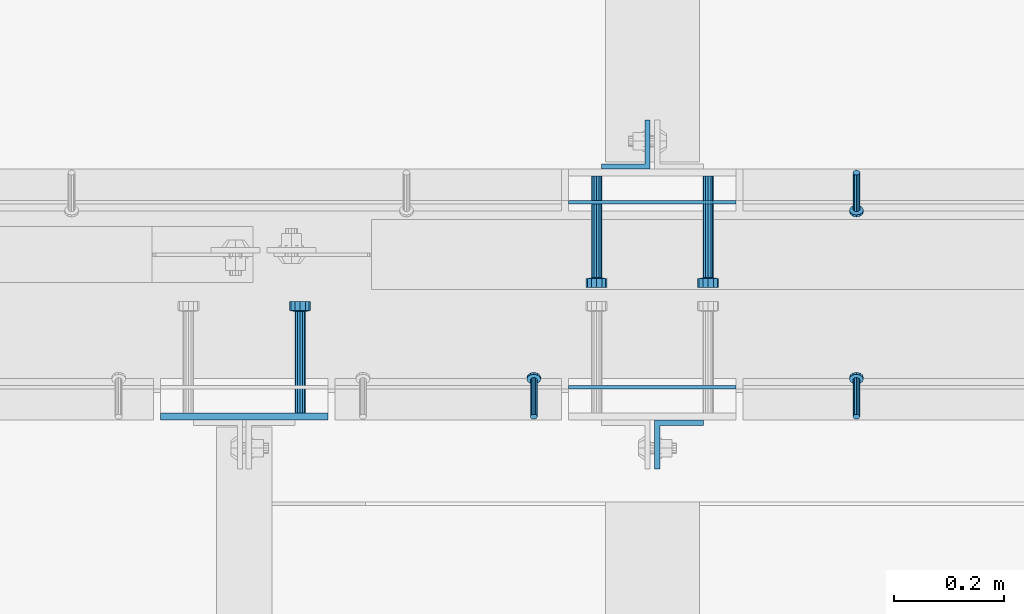
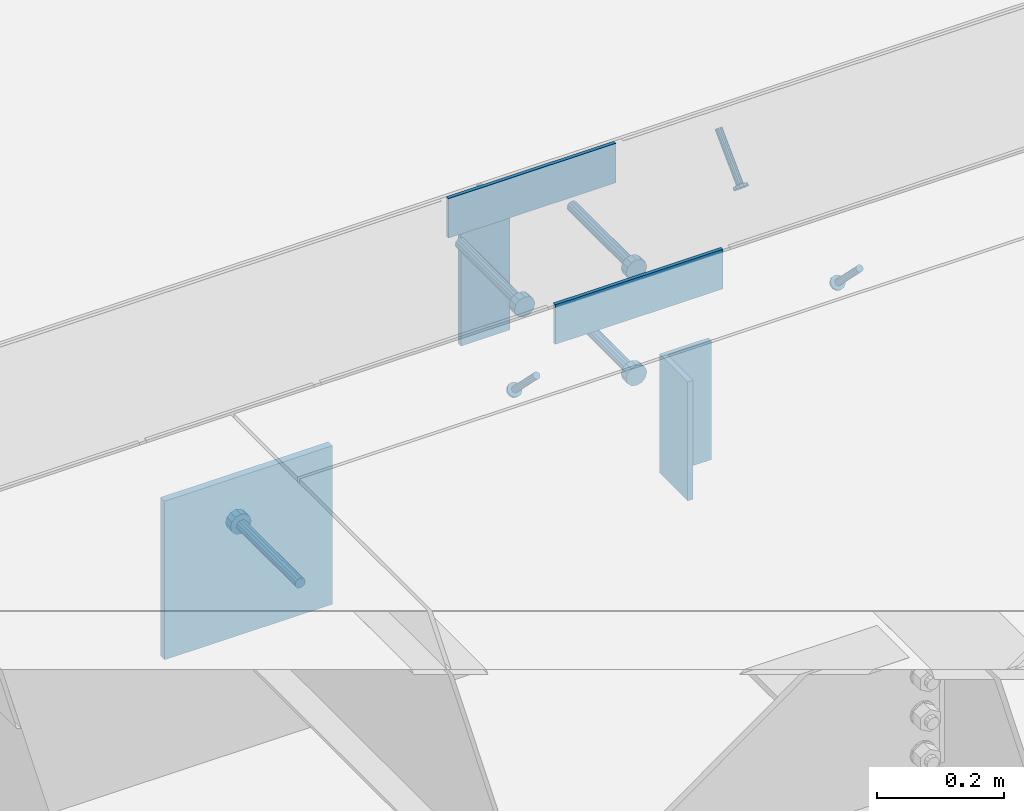
# One storey, part 2009 of 3843: 9 beams, 3 members, 8 elements without a shape of their own.
"""IFC2X3 building model written with IfcOpenShell, lengths in millimetres."""

from ifc_helpers import new_model, si_unit, frame, origin_with_axes, place, context, subcontext, project, spatial, faceted_brep, material, type_object, element, aggregate, save


model = new_model("IFC2X3")

# Units and contexts
model_context = context("Model", 3, precision=1e-05, world=origin_with_axes())
body_context = subcontext(model_context, "Body", "Model", "MODEL_VIEW")
ifc_project = project(units=[si_unit("LENGTHUNIT", "METRE", prefix="MILLI"), si_unit("AREAUNIT", "SQUARE_METRE"), si_unit("VOLUMEUNIT", "CUBIC_METRE"), si_unit("MASSUNIT", "GRAM", prefix="KILO"), si_unit("TIMEUNIT", "SECOND"), si_unit("PLANEANGLEUNIT", "RADIAN"), si_unit("SOLIDANGLEUNIT", "STERADIAN"), si_unit("THERMODYNAMICTEMPERATUREUNIT", "DEGREE_CELSIUS"), si_unit("LUMINOUSINTENSITYUNIT", "LUMEN")], contexts=[model_context])

# Site, building, storey
site_placement = place(None, origin_with_axes())
site = spatial("IfcSite", under=ifc_project, at=site_placement, CompositionType="ELEMENT")
building_placement = place(site_placement, origin_with_axes())
building = spatial("IfcBuilding", under=site, at=building_placement, Name="Undefined", CompositionType="ELEMENT")
storey_placement = place(building_placement, origin_with_axes())
storey = spatial("IfcBuildingStorey", under=building, at=storey_placement, Name="Undefined", CompositionType="ELEMENT", Elevation=0.0)

# Assembly, member
assembly_1_placement = place(storey_placement, origin_with_axes())
assembly_1 = element("IfcElementAssembly", 1, at=assembly_1_placement, inside=storey, Name="ANGLE", AssemblyPlace="NOTDEFINED", PredefinedType="RIGID_FRAME")
ifc_material_1 = material(Name="STEEL/A108")
member_type = type_object("IfcMemberType", PredefinedType="NOTDEFINED")
member_1_placement = place(assembly_1_placement, frame((43141.9272929978, 20456.5250055596, 30397.4500030518), z_axis=(1.0, 0.0, 0.0), x_axis=(0.0, -0.707106781186548, -0.707106781186548)))
member_1 = element("IfcMember", 2, at=member_1_placement, type_object=member_type, material=ifc_material_1, Name="HEADED STUD ANCHOR", context=body_context, shape_type="Brep", body=[
    faceted_brep([(7.27595761418343e-12, -3.18000006675175, 5.5), (0.0, -5.49999999998363, 3.1800000667572), (94.4879985803855, -5.50000000011278, 3.1800000667572), (94.4879985803782, -3.18000006687362, 5.5), (0.0, -6.3499999046162, 0.0), (94.4879985803855, -6.34999990474535, 0.0), (0.0, -5.49999999998363, -3.1800000667572), (94.4879985803855, -5.50000000011278, -3.1800000667572), (7.27595761418343e-12, -3.18000006675175, -5.5), (94.4879985803782, -3.18000006687362, -5.5), (7.27595761418343e-12, -1.81898940354586e-12, -6.34999990463257), (94.4879985803782, -1.20053300634027e-10, -6.34999990463257), (0.0, 3.18000006675175, -5.5), (94.4879985803709, 3.18000006663351, -5.5), (7.27595761418343e-12, 5.49999999998363, -3.1800000667572), (94.4879985803709, 5.49999999987267, -3.1800000667572), (7.27595761418343e-12, 6.3499999046162, 0.0), (94.4879985803673, 6.34999990450706, 0.0), (7.27595761418343e-12, 5.49999999998363, 3.1800000667572), (94.4879985803709, 5.49999999987267, 3.1800000667572), (0.0, 3.18000006675175, 5.5), (94.4879985803709, 3.18000006663351, 5.5), (7.27595761418343e-12, -1.81898940354586e-12, 6.34999990463257), (94.4879985803782, -1.20053300634027e-10, 6.34999990463257), (96.5199985498621, -10.9899997712273, 6.34999990463257), (96.5199985498548, -6.34000015270249, 10.9899997711182), (96.5199985498621, -12.6999998093743, 0.0), (96.5199985498621, -10.9899997712273, -6.34999990463257), (96.5199985498548, -6.34000015270249, -10.9899997711182), (96.5199985498475, -1.21872290037572e-10, -12.6899995803833), (96.5199985498402, 6.34000015245874, -10.9899997711182), (96.519998549833, 10.9899997709817, -6.34999990463257), (96.519998549833, 12.6999998091305, 0.0), (96.519998549833, 10.9899997709817, 6.34999990463257), (96.5199985498402, 6.34000015245874, 10.9899997711182), (96.5199985498475, -1.21872290037572e-10, 12.6899995803833), (101.599998473539, -10.9899997712328, 6.34999990463257), (101.599998473532, -6.34000015270976, 10.9899997711182), (101.599998473539, -12.6999998093797, 0.0), (101.599998473539, -10.9899997712328, -6.34999990463257), (101.599998473532, -6.34000015270976, -10.9899997711182), (101.599998473524, -1.29148247651756e-10, -12.6899995803833), (101.599998473517, 6.34000015245329, -10.9899997711182), (101.59999847351, 10.9899997709763, -6.34999990463257), (101.599998473503, 12.6999998091196, 0.0), (101.59999847351, 10.9899997709763, 6.34999990463257), (101.599998473517, 6.34000015245329, 10.9899997711182), (101.599998473524, -1.29148247651756e-10, 12.6899995803833)], [[[0, 1, 2, 3]], [[1, 4, 5, 2]], [[4, 6, 7, 5]], [[6, 8, 9, 7]], [[8, 10, 11, 9]], [[10, 12, 13, 11]], [[12, 14, 15, 13]], [[14, 16, 17, 15]], [[16, 18, 19, 17]], [[18, 20, 21, 19]], [[20, 22, 23, 21]], [[22, 0, 3, 23]], [[22, 20, 18, 16, 14, 12, 10, 8, 6, 4, 1, 0]], [[3, 2, 24, 25]], [[2, 5, 26, 24]], [[5, 7, 27, 26]], [[7, 9, 28, 27]], [[9, 11, 29, 28]], [[11, 13, 30, 29]], [[13, 15, 31, 30]], [[15, 17, 32, 31]], [[17, 19, 33, 32]], [[19, 21, 34, 33]], [[21, 23, 35, 34]], [[23, 3, 25, 35]], [[25, 24, 36, 37]], [[24, 26, 38, 36]], [[26, 27, 39, 38]], [[27, 28, 40, 39]], [[28, 29, 41, 40]], [[29, 30, 42, 41]], [[30, 31, 43, 42]], [[31, 32, 44, 43]], [[32, 33, 45, 44]], [[33, 34, 46, 45]], [[34, 35, 47, 46]], [[35, 25, 37, 47]], [[38, 39, 40, 41, 42, 43, 44, 45, 46, 47, 37, 36]]]),
])
aggregate(assembly_1, [member_1])

assembly_2_placement = place(storey_placement, origin_with_axes())
assembly_2 = element("IfcElementAssembly", 3, at=assembly_2_placement, inside=storey, Name="ANGLE", AssemblyPlace="NOTDEFINED", PredefinedType="RIGID_FRAME")
member_2_placement = place(assembly_2_placement, frame((43141.8902526855, 20012.024996964, 30397.4500030518), z_axis=(-1.0, 0.0, 0.0), x_axis=(5.70000238222118e-08, 0.707106781186546, -0.707106781186546)))
member_2 = element("IfcMember", 4, at=member_2_placement, type_object=member_type, material=ifc_material_1, Name="HEADED STUD ANCHOR", context=body_context, shape_type="Brep", body=[
    faceted_brep([(7.27595761418343e-12, -3.18000006675175, 5.5), (0.0, -5.49999999998363, 3.1800000667572), (94.4879985803855, -5.50000000011278, 3.1800000667572), (94.4879985803782, -3.18000006687362, 5.5), (0.0, -6.3499999046162, 0.0), (94.4879985803855, -6.34999990474535, 0.0), (0.0, -5.49999999998363, -3.1800000667572), (94.4879985803855, -5.50000000011278, -3.1800000667572), (7.27595761418343e-12, -3.18000006675175, -5.5), (94.4879985803782, -3.18000006687362, -5.5), (7.27595761418343e-12, -1.81898940354586e-12, -6.34999990463257), (94.4879985803782, -1.20053300634027e-10, -6.34999990463257), (0.0, 3.18000006675175, -5.5), (94.4879985803709, 3.18000006663351, -5.5), (7.27595761418343e-12, 5.49999999998363, -3.1800000667572), (94.4879985803709, 5.49999999987267, -3.1800000667572), (7.27595761418343e-12, 6.3499999046162, 0.0), (94.4879985803673, 6.34999990450706, 0.0), (7.27595761418343e-12, 5.49999999998363, 3.1800000667572), (94.4879985803709, 5.49999999987267, 3.1800000667572), (0.0, 3.18000006675175, 5.5), (94.4879985803709, 3.18000006663351, 5.5), (7.27595761418343e-12, -1.81898940354586e-12, 6.34999990463257), (94.4879985803782, -1.20053300634027e-10, 6.34999990463257), (96.5199985498621, -10.9899997712273, 6.34999990463257), (96.5199985498548, -6.34000015270249, 10.9899997711182), (96.5199985498621, -12.6999998093743, 0.0), (96.5199985498621, -10.9899997712273, -6.34999990463257), (96.5199985498548, -6.34000015270249, -10.9899997711182), (96.5199985498475, -1.21872290037572e-10, -12.6899995803833), (96.5199985498402, 6.34000015245874, -10.9899997711182), (96.519998549833, 10.9899997709817, -6.34999990463257), (96.519998549833, 12.6999998091305, 0.0), (96.519998549833, 10.9899997709817, 6.34999990463257), (96.5199985498402, 6.34000015245874, 10.9899997711182), (96.5199985498475, -1.21872290037572e-10, 12.6899995803833), (101.599998473539, -10.9899997712328, 6.34999990463257), (101.599998473532, -6.34000015270976, 10.9899997711182), (101.599998473539, -12.6999998093797, 0.0), (101.599998473539, -10.9899997712328, -6.34999990463257), (101.599998473532, -6.34000015270976, -10.9899997711182), (101.599998473524, -1.29148247651756e-10, -12.6899995803833), (101.599998473517, 6.34000015245329, -10.9899997711182), (101.59999847351, 10.9899997709763, -6.34999990463257), (101.599998473503, 12.6999998091196, 0.0), (101.59999847351, 10.9899997709763, 6.34999990463257), (101.599998473517, 6.34000015245329, 10.9899997711182), (101.599998473524, -1.29148247651756e-10, 12.6899995803833)], [[[0, 1, 2, 3]], [[1, 4, 5, 2]], [[4, 6, 7, 5]], [[6, 8, 9, 7]], [[8, 10, 11, 9]], [[10, 12, 13, 11]], [[12, 14, 15, 13]], [[14, 16, 17, 15]], [[16, 18, 19, 17]], [[18, 20, 21, 19]], [[20, 22, 23, 21]], [[22, 0, 3, 23]], [[22, 20, 18, 16, 14, 12, 10, 8, 6, 4, 1, 0]], [[3, 2, 24, 25]], [[2, 5, 26, 24]], [[5, 7, 27, 26]], [[7, 9, 28, 27]], [[9, 11, 29, 28]], [[11, 13, 30, 29]], [[13, 15, 31, 30]], [[15, 17, 32, 31]], [[17, 19, 33, 32]], [[19, 21, 34, 33]], [[21, 23, 35, 34]], [[23, 3, 25, 35]], [[25, 24, 36, 37]], [[24, 26, 38, 36]], [[26, 27, 39, 38]], [[27, 28, 40, 39]], [[28, 29, 41, 40]], [[29, 30, 42, 41]], [[30, 31, 43, 42]], [[31, 32, 44, 43]], [[32, 33, 45, 44]], [[33, 34, 46, 45]], [[34, 35, 47, 46]], [[35, 25, 37, 47]], [[38, 39, 40, 41, 42, 43, 44, 45, 46, 47, 37, 36]]]),
])
aggregate(assembly_2, [member_2])

assembly_3_placement = place(storey_placement, origin_with_axes())
assembly_3 = element("IfcElementAssembly", 5, at=assembly_3_placement, inside=storey, Name="ANGLE", AssemblyPlace="NOTDEFINED", PredefinedType="RIGID_FRAME")
member_3_placement = place(assembly_3_placement, frame((42554.5250053596, 20012.0249971482, 30397.4500030497), z_axis=(-1.0, 0.0, 0.0), x_axis=(5.70000238222118e-08, 0.707106781186546, -0.707106781186546)))
member_3 = element("IfcMember", 6, at=member_3_placement, type_object=member_type, material=ifc_material_1, Name="HEADED STUD ANCHOR", context=body_context, shape_type="Brep", body=[
    faceted_brep([(7.27595761418343e-12, -3.18000006675175, 5.5), (0.0, -5.49999999998363, 3.1800000667572), (94.4879985803855, -5.50000000011278, 3.1800000667572), (94.4879985803782, -3.18000006687362, 5.5), (0.0, -6.3499999046162, 0.0), (94.4879985803855, -6.34999990474535, 0.0), (0.0, -5.49999999998363, -3.1800000667572), (94.4879985803855, -5.50000000011278, -3.1800000667572), (7.27595761418343e-12, -3.18000006675175, -5.5), (94.4879985803782, -3.18000006687362, -5.5), (7.27595761418343e-12, -1.81898940354586e-12, -6.34999990463257), (94.4879985803782, -1.20053300634027e-10, -6.34999990463257), (0.0, 3.18000006675175, -5.5), (94.4879985803709, 3.18000006663351, -5.5), (7.27595761418343e-12, 5.49999999998363, -3.1800000667572), (94.4879985803709, 5.49999999987267, -3.1800000667572), (7.27595761418343e-12, 6.3499999046162, 0.0), (94.4879985803673, 6.34999990450706, 0.0), (7.27595761418343e-12, 5.49999999998363, 3.1800000667572), (94.4879985803709, 5.49999999987267, 3.1800000667572), (0.0, 3.18000006675175, 5.5), (94.4879985803709, 3.18000006663351, 5.5), (7.27595761418343e-12, -1.81898940354586e-12, 6.34999990463257), (94.4879985803782, -1.20053300634027e-10, 6.34999990463257), (96.5199985498621, -10.9899997712273, 6.34999990463257), (96.5199985498548, -6.34000015270249, 10.9899997711182), (96.5199985498621, -12.6999998093743, 0.0), (96.5199985498621, -10.9899997712273, -6.34999990463257), (96.5199985498548, -6.34000015270249, -10.9899997711182), (96.5199985498475, -1.21872290037572e-10, -12.6899995803833), (96.5199985498402, 6.34000015245874, -10.9899997711182), (96.519998549833, 10.9899997709817, -6.34999990463257), (96.519998549833, 12.6999998091305, 0.0), (96.519998549833, 10.9899997709817, 6.34999990463257), (96.5199985498402, 6.34000015245874, 10.9899997711182), (96.5199985498475, -1.21872290037572e-10, 12.6899995803833), (101.599998473539, -10.9899997712328, 6.34999990463257), (101.599998473532, -6.34000015270976, 10.9899997711182), (101.599998473539, -12.6999998093797, 0.0), (101.599998473539, -10.9899997712328, -6.34999990463257), (101.599998473532, -6.34000015270976, -10.9899997711182), (101.599998473524, -1.29148247651756e-10, -12.6899995803833), (101.599998473517, 6.34000015245329, -10.9899997711182), (101.59999847351, 10.9899997709763, -6.34999990463257), (101.599998473503, 12.6999998091196, 0.0), (101.59999847351, 10.9899997709763, 6.34999990463257), (101.599998473517, 6.34000015245329, 10.9899997711182), (101.599998473524, -1.29148247651756e-10, 12.6899995803833)], [[[0, 1, 2, 3]], [[1, 4, 5, 2]], [[4, 6, 7, 5]], [[6, 8, 9, 7]], [[8, 10, 11, 9]], [[10, 12, 13, 11]], [[12, 14, 15, 13]], [[14, 16, 17, 15]], [[16, 18, 19, 17]], [[18, 20, 21, 19]], [[20, 22, 23, 21]], [[22, 0, 3, 23]], [[22, 20, 18, 16, 14, 12, 10, 8, 6, 4, 1, 0]], [[3, 2, 24, 25]], [[2, 5, 26, 24]], [[5, 7, 27, 26]], [[7, 9, 28, 27]], [[9, 11, 29, 28]], [[11, 13, 30, 29]], [[13, 15, 31, 30]], [[15, 17, 32, 31]], [[17, 19, 33, 32]], [[19, 21, 34, 33]], [[21, 23, 35, 34]], [[23, 3, 25, 35]], [[25, 24, 36, 37]], [[24, 26, 38, 36]], [[26, 27, 39, 38]], [[27, 28, 40, 39]], [[28, 29, 41, 40]], [[29, 30, 42, 41]], [[30, 31, 43, 42]], [[31, 32, 44, 43]], [[32, 33, 45, 44]], [[33, 34, 46, 45]], [[34, 35, 47, 46]], [[35, 25, 37, 47]], [[38, 39, 40, 41, 42, 43, 44, 45, 46, 47, 37, 36]]]),
])
aggregate(assembly_3, [member_3])

# Assembly, beam
assembly_4_placement = place(storey_placement, origin_with_axes())
assembly_4 = element("IfcElementAssembly", 7, at=assembly_4_placement, inside=storey, Name="EMBED PLATE", AssemblyPlace="NOTDEFINED", PredefinedType="RIGID_FRAME")
ifc_material_2 = material(Name="STEEL/A36")
beam_type_1 = type_object("IfcBeamType", PredefinedType="NOTDEFINED")
beam_1_placement = place(assembly_4_placement, frame((42618.025, 20065.9999969482, 30441.9), z_axis=(0.0, 0.0, 1.0), x_axis=(1.0, 0.0, 0.0)))
beam_1 = element("IfcBeam", 8, at=beam_1_placement, type_object=beam_type_1, material=ifc_material_2, Name="PLATE", context=body_context, shape_type="Brep", body=[
    faceted_brep([(0.0, 3.17500000000291, -38.0999999999985), (0.0, 3.17500000000291, 38.0999999999985), (304.800000000003, 3.17499999999927, 38.0999999999985), (304.800000000003, 3.17499999999927, -38.0999999999985), (0.0, -3.17500000000291, 38.0999999999985), (304.800000000003, -3.17499999999927, 38.0999999999985), (0.0, -3.17500000000291, -38.0999999999985), (304.800000000003, -3.17499999999927, -38.0999999999985)], [[[0, 1, 2, 3]], [[1, 4, 5, 2]], [[4, 6, 7, 5]], [[6, 0, 3, 7]], [[5, 7, 3, 2]], [[6, 4, 1, 0]]]),
])
aggregate(assembly_4, [beam_1])

assembly_5_placement = place(storey_placement, origin_with_axes())
assembly_5 = element("IfcElementAssembly", 9, at=assembly_5_placement, inside=storey, Name="EMBED PLATE", AssemblyPlace="NOTDEFINED", PredefinedType="RIGID_FRAME")
beam_2_placement = place(assembly_5_placement, frame((42922.825, 20402.5500030518, 30441.9), z_axis=(0.0, 0.0, 1.0), x_axis=(-1.0, 0.0, 0.0)))
beam_2 = element("IfcBeam", 10, at=beam_2_placement, type_object=beam_type_1, material=ifc_material_2, Name="PLATE", context=body_context, shape_type="Brep", body=[
    faceted_brep([(0.0, 3.17500000000291, -38.0999999999985), (0.0, 3.17500000000291, 38.0999999999985), (304.800000000003, 3.17499999999927, 38.0999999999985), (304.800000000003, 3.17499999999927, -38.0999999999985), (0.0, -3.17500000000291, 38.0999999999985), (304.800000000003, -3.17499999999927, 38.0999999999985), (0.0, -3.17500000000291, -38.0999999999985), (304.800000000003, -3.17499999999927, -38.0999999999985)], [[[0, 1, 2, 3]], [[1, 4, 5, 2]], [[4, 6, 7, 5]], [[6, 0, 3, 7]], [[5, 7, 3, 2]], [[6, 4, 1, 0]]]),
])

assembly_6_placement = place(storey_placement, origin_with_axes())
assembly_6 = element("IfcElementAssembly", 11, at=assembly_6_placement, inside=storey, Name="EMBED PLATE", AssemblyPlace="NOTDEFINED", PredefinedType="RIGID_FRAME")
beam_type_2 = type_object("IfcBeamType", PredefinedType="NOTDEFINED")
beam_3_placement = place(assembly_6_placement, frame((42027.475, 20012.0249969482, 30397.45), z_axis=(1.0, 0.0, 0.0), x_axis=(0.0, 0.0, -1.0)))
beam_3 = element("IfcBeam", 12, at=beam_3_placement, type_object=beam_type_2, material=ifc_material_2, Name="EMBED PLATE", context=body_context, shape_type="Brep", body=[
    faceted_brep([(-1.0550138540566e-10, 6.34999999999854, -152.400000000664), (1.0550138540566e-10, 6.34999999999854, 152.400000000656), (304.799999999999, 6.34999999999854, 152.400000000001), (304.799999999999, 6.34999999999854, -152.400000000001), (1.0550138540566e-10, -6.34999999999854, 152.400000000656), (304.799999999999, -6.34999999999854, 152.400000000001), (-1.0550138540566e-10, -6.34999999999854, -152.400000000664), (304.799999999999, -6.34999999999854, -152.400000000001)], [[[0, 1, 2, 3]], [[1, 4, 5, 2]], [[4, 6, 7, 5]], [[6, 0, 3, 7]], [[5, 7, 3, 2]], [[6, 4, 1, 0]]]),
])

assembly_7_placement = place(storey_placement, origin_with_axes())
assembly_7 = element("IfcElementAssembly", 13, at=assembly_7_placement, inside=storey, Name="BEAM", AssemblyPlace="NOTDEFINED", PredefinedType="RIGID_FRAME")
beam_type_3 = type_object("IfcBeamType", Name="L3-1/2X3-1/2X3/8", PredefinedType="NOTDEFINED")
beam_4_placement = place(assembly_7_placement, frame((42722.00625, 20507.3250030517, 30365.7), z_axis=(-1.0, 0.0, 0.0), x_axis=(0.0, 0.0, -1.0)))
beam_4 = element("IfcBeam", 14, at=beam_4_placement, type_object=beam_type_3, material=ifc_material_2, Name="ANGLE", ObjectType="L3-1/2X3-1/2X3/8", context=body_context, shape_type="Brep", body=[
    faceted_brep([(-3.63797880709171e-12, 44.4499999999971, -44.4500000000007), (-3.63797880709171e-12, 44.4499999999971, 44.4500000000007), (228.600000000006, 44.4499999999971, 44.4500000000007), (228.600000000006, 44.4499999999971, -44.4500000000007), (0.0, 34.9250000000029, 44.4500000000007), (228.600000000006, 34.9250000000029, 44.4500000000007), (0.0, 34.9250000000029, -34.9250000000029), (228.600000000006, 34.9250000000029, -34.9249999999993), (0.0, -44.4499999999971, -34.9249999999993), (228.600000000006, -44.4499999999971, -34.9249999999993), (3.63797880709171e-12, -44.4499999999971, -44.4500000000007), (228.600000000006, -44.4499999999971, -44.4500000000007)], [[[0, 1, 2, 3]], [[1, 4, 5, 2]], [[4, 6, 7, 5]], [[6, 8, 9, 7]], [[8, 10, 11, 9]], [[10, 0, 3, 11]], [[5, 7, 9, 11, 3, 2]], [[10, 8, 6, 4, 1, 0]]]),
])
aggregate(assembly_7, [beam_4])

assembly_8_placement = place(storey_placement, origin_with_axes())
assembly_8 = element("IfcElementAssembly", 15, at=assembly_8_placement, inside=storey, Name="BEAM", AssemblyPlace="NOTDEFINED", PredefinedType="RIGID_FRAME")
beam_5_placement = place(assembly_8_placement, frame((42818.84375, 19961.2249969482, 30365.7), z_axis=(1.0, 0.0, 0.0), x_axis=(0.0, 0.0, -1.0)))
beam_5 = element("IfcBeam", 16, at=beam_5_placement, type_object=beam_type_3, material=ifc_material_2, Name="ANGLE", ObjectType="L3-1/2X3-1/2X3/8", context=body_context, shape_type="Brep", body=[
    faceted_brep([(-3.63797880709171e-12, 44.4499999999971, -44.4500000000007), (-3.63797880709171e-12, 44.4499999999971, 44.4500000000007), (228.600000000006, 44.4499999999971, 44.4500000000007), (228.600000000006, 44.4499999999971, -44.4500000000007), (0.0, 34.9250000000029, 44.4500000000007), (228.600000000006, 34.9250000000029, 44.4500000000007), (0.0, 34.9250000000029, -34.9250000000029), (228.600000000006, 34.9250000000029, -34.9249999999993), (0.0, -44.4499999999971, -34.9249999999993), (228.600000000006, -44.4499999999971, -34.9249999999993), (3.63797880709171e-12, -44.4499999999971, -44.4500000000007), (228.600000000006, -44.4499999999971, -44.4500000000007)], [[[0, 1, 2, 3]], [[1, 4, 5, 2]], [[4, 6, 7, 5]], [[6, 8, 9, 7]], [[8, 10, 11, 9]], [[10, 0, 3, 11]], [[5, 7, 9, 11, 3, 2]], [[10, 8, 6, 4, 1, 0]]]),
])
aggregate(assembly_8, [beam_5])

# Beam
beam_type_4 = type_object("IfcBeamType", PredefinedType="NOTDEFINED")
beam_6_placement = place(assembly_5_placement, frame((42872.025, 20450.1750030518, 30346.65), z_axis=(1.0, 0.0, 0.0), x_axis=(0.0, -1.0, 0.0)))
beam_6 = element("IfcBeam", 17, at=beam_6_placement, type_object=beam_type_4, material=ifc_material_1, Name="HEADED STUD ANCHOR", context=body_context, shape_type="Brep", body=[
    faceted_brep([(0.0, -9.52000045776367, 0.0), (0.0, -8.25, -4.76000022888184), (184.912000000004, -8.25, -4.76000022888184), (184.912000000004, -9.52000045776367, 0.0), (0.0, -4.76000022888184, -8.25), (184.912000000004, -4.76000022888184, -8.25), (0.0, 0.0, -9.52000045776367), (184.912000000004, 0.0, -9.52000045776367), (0.0, 4.76000022888184, -8.25), (184.912000000004, 4.76000022888184, -8.25), (0.0, 8.25, -4.76000022888184), (184.912000000004, 8.25, -4.76000022888184), (0.0, 9.52000045776367, 0.0), (184.912000000004, 9.52000045776367, 0.0), (0.0, 8.25, 4.76000022888184), (184.912000000004, 8.25, 4.76000022888184), (0.0, 4.76000022888184, 8.25), (184.912000000004, 4.76000022888184, 8.25), (0.0, 0.0, 9.52000045776367), (184.912000000004, 0.0, 9.52000045776367), (0.0, -4.76000022888184, 8.25), (184.912000000004, -4.76000022888184, 8.25), (0.0, -8.25, 4.76000022888184), (184.912000000004, -8.25, 4.76000022888184), (186.944000000003, -16.5, -9.52000045776367), (186.944000000003, -19.0499992370605, 0.0), (186.944000000003, -9.52000045776367, -16.5), (186.944000000003, 0.0, -19.0499992370605), (186.944000000003, 9.52000045776367, -16.5), (186.944000000003, 16.5, -9.52000045776367), (186.944000000003, 19.0499992370605, 0.0), (186.944000000003, 16.5, 9.52000045776367), (186.944000000003, 9.52000045776367, 16.5), (186.944000000003, 0.0, 19.0499992370605), (186.944000000003, -9.52000045776367, 16.5), (186.944000000003, -16.5, 9.52000045776367), (203.199999999997, -16.5, -9.52000045776367), (203.199999999997, -19.0499992370605, 0.0), (203.199999999997, -9.52000045776367, -16.5), (203.199999999997, 0.0, -19.0499992370605), (203.199999999997, 9.52000045776367, -16.5), (203.199999999997, 16.5, -9.52000045776367), (203.199999999997, 19.0499992370605, 0.0), (203.199999999997, 16.5, 9.52000045776367), (203.199999999997, 9.52000045776367, 16.5), (203.199999999997, 0.0, 19.0499992370605), (203.199999999997, -9.52000045776367, 16.5), (203.199999999997, -16.5, 9.52000045776367)], [[[0, 1, 2, 3]], [[1, 4, 5, 2]], [[4, 6, 7, 5]], [[6, 8, 9, 7]], [[8, 10, 11, 9]], [[10, 12, 13, 11]], [[12, 14, 15, 13]], [[14, 16, 17, 15]], [[16, 18, 19, 17]], [[18, 20, 21, 19]], [[20, 22, 23, 21]], [[22, 0, 3, 23]], [[22, 20, 18, 16, 14, 12, 10, 8, 6, 4, 1, 0]], [[3, 2, 24, 25]], [[2, 5, 26, 24]], [[5, 7, 27, 26]], [[7, 9, 28, 27]], [[9, 11, 29, 28]], [[11, 13, 30, 29]], [[13, 15, 31, 30]], [[15, 17, 32, 31]], [[17, 19, 33, 32]], [[19, 21, 34, 33]], [[21, 23, 35, 34]], [[23, 3, 25, 35]], [[25, 24, 36, 37]], [[24, 26, 38, 36]], [[26, 27, 39, 38]], [[27, 28, 40, 39]], [[28, 29, 41, 40]], [[29, 30, 42, 41]], [[30, 31, 43, 42]], [[31, 32, 44, 43]], [[32, 33, 45, 44]], [[33, 34, 46, 45]], [[34, 35, 47, 46]], [[35, 25, 37, 47]], [[38, 39, 40, 41, 42, 43, 44, 45, 46, 47, 37, 36]]]),
])

beam_7_placement = place(assembly_5_placement, frame((42872.025, 20450.1750030518, 30143.45), z_axis=(1.0, 0.0, 0.0), x_axis=(0.0, -1.0, 0.0)))
beam_7 = element("IfcBeam", 18, at=beam_7_placement, type_object=beam_type_4, material=ifc_material_1, Name="HEADED STUD ANCHOR", context=body_context, shape_type="Brep", body=[
    faceted_brep([(0.0, -9.52000045776367, 0.0), (0.0, -8.25, -4.76000022888184), (184.912000000004, -8.25, -4.76000022888184), (184.912000000004, -9.52000045776367, 0.0), (0.0, -4.76000022888184, -8.25), (184.912000000004, -4.76000022888184, -8.25), (0.0, 0.0, -9.52000045776367), (184.912000000004, 0.0, -9.52000045776367), (0.0, 4.76000022888184, -8.25), (184.912000000004, 4.76000022888184, -8.25), (0.0, 8.25, -4.76000022888184), (184.912000000004, 8.25, -4.76000022888184), (0.0, 9.52000045776367, 0.0), (184.912000000004, 9.52000045776367, 0.0), (0.0, 8.25, 4.76000022888184), (184.912000000004, 8.25, 4.76000022888184), (0.0, 4.76000022888184, 8.25), (184.912000000004, 4.76000022888184, 8.25), (0.0, 0.0, 9.52000045776367), (184.912000000004, 0.0, 9.52000045776367), (0.0, -4.76000022888184, 8.25), (184.912000000004, -4.76000022888184, 8.25), (0.0, -8.25, 4.76000022888184), (184.912000000004, -8.25, 4.76000022888184), (186.944000000003, -16.5, -9.52000045776367), (186.944000000003, -19.0499992370605, 0.0), (186.944000000003, -9.52000045776367, -16.5), (186.944000000003, 0.0, -19.0499992370605), (186.944000000003, 9.52000045776367, -16.5), (186.944000000003, 16.5, -9.52000045776367), (186.944000000003, 19.0499992370605, 0.0), (186.944000000003, 16.5, 9.52000045776367), (186.944000000003, 9.52000045776367, 16.5), (186.944000000003, 0.0, 19.0499992370605), (186.944000000003, -9.52000045776367, 16.5), (186.944000000003, -16.5, 9.52000045776367), (203.199999999997, -16.5, -9.52000045776367), (203.199999999997, -19.0499992370605, 0.0), (203.199999999997, -9.52000045776367, -16.5), (203.199999999997, 0.0, -19.0499992370605), (203.199999999997, 9.52000045776367, -16.5), (203.199999999997, 16.5, -9.52000045776367), (203.199999999997, 19.0499992370605, 0.0), (203.199999999997, 16.5, 9.52000045776367), (203.199999999997, 9.52000045776367, 16.5), (203.199999999997, 0.0, 19.0499992370605), (203.199999999997, -9.52000045776367, 16.5), (203.199999999997, -16.5, 9.52000045776367)], [[[0, 1, 2, 3]], [[1, 4, 5, 2]], [[4, 6, 7, 5]], [[6, 8, 9, 7]], [[8, 10, 11, 9]], [[10, 12, 13, 11]], [[12, 14, 15, 13]], [[14, 16, 17, 15]], [[16, 18, 19, 17]], [[18, 20, 21, 19]], [[20, 22, 23, 21]], [[22, 0, 3, 23]], [[22, 20, 18, 16, 14, 12, 10, 8, 6, 4, 1, 0]], [[3, 2, 24, 25]], [[2, 5, 26, 24]], [[5, 7, 27, 26]], [[7, 9, 28, 27]], [[9, 11, 29, 28]], [[11, 13, 30, 29]], [[13, 15, 31, 30]], [[15, 17, 32, 31]], [[17, 19, 33, 32]], [[19, 21, 34, 33]], [[21, 23, 35, 34]], [[23, 3, 25, 35]], [[25, 24, 36, 37]], [[24, 26, 38, 36]], [[26, 27, 39, 38]], [[27, 28, 40, 39]], [[28, 29, 41, 40]], [[29, 30, 42, 41]], [[30, 31, 43, 42]], [[31, 32, 44, 43]], [[32, 33, 45, 44]], [[33, 34, 46, 45]], [[34, 35, 47, 46]], [[35, 25, 37, 47]], [[38, 39, 40, 41, 42, 43, 44, 45, 46, 47, 37, 36]]]),
])

beam_8_placement = place(assembly_5_placement, frame((42668.825, 20450.1750030518, 30346.65), z_axis=(1.0, 0.0, 0.0), x_axis=(0.0, -1.0, 0.0)))
beam_8 = element("IfcBeam", 19, at=beam_8_placement, type_object=beam_type_4, material=ifc_material_2, Name="PLATE", context=body_context, shape_type="Brep", body=[
    faceted_brep([(0.0, -9.52000045776367, 0.0), (0.0, -8.25, -4.76000022888184), (184.912000000004, -8.25, -4.76000022888184), (184.912000000004, -9.52000045776367, 0.0), (0.0, -4.76000022888184, -8.25), (184.912000000004, -4.76000022888184, -8.25), (0.0, 0.0, -9.52000045776367), (184.912000000004, 0.0, -9.52000045776367), (0.0, 4.76000022888184, -8.25), (184.912000000004, 4.76000022888184, -8.25), (0.0, 8.25, -4.76000022888184), (184.912000000004, 8.25, -4.76000022888184), (0.0, 9.52000045776367, 0.0), (184.912000000004, 9.52000045776367, 0.0), (0.0, 8.25, 4.76000022888184), (184.912000000004, 8.25, 4.76000022888184), (0.0, 4.76000022888184, 8.25), (184.912000000004, 4.76000022888184, 8.25), (0.0, 0.0, 9.52000045776367), (184.912000000004, 0.0, 9.52000045776367), (0.0, -4.76000022888184, 8.25), (184.912000000004, -4.76000022888184, 8.25), (0.0, -8.25, 4.76000022888184), (184.912000000004, -8.25, 4.76000022888184), (186.944000000003, -16.5, -9.52000045776367), (186.944000000003, -19.0499992370605, 0.0), (186.944000000003, -9.52000045776367, -16.5), (186.944000000003, 0.0, -19.0499992370605), (186.944000000003, 9.52000045776367, -16.5), (186.944000000003, 16.5, -9.52000045776367), (186.944000000003, 19.0499992370605, 0.0), (186.944000000003, 16.5, 9.52000045776367), (186.944000000003, 9.52000045776367, 16.5), (186.944000000003, 0.0, 19.0499992370605), (186.944000000003, -9.52000045776367, 16.5), (186.944000000003, -16.5, 9.52000045776367), (203.199999999997, -16.5, -9.52000045776367), (203.199999999997, -19.0499992370605, 0.0), (203.199999999997, -9.52000045776367, -16.5), (203.199999999997, 0.0, -19.0499992370605), (203.199999999997, 9.52000045776367, -16.5), (203.199999999997, 16.5, -9.52000045776367), (203.199999999997, 19.0499992370605, 0.0), (203.199999999997, 16.5, 9.52000045776367), (203.199999999997, 9.52000045776367, 16.5), (203.199999999997, 0.0, 19.0499992370605), (203.199999999997, -9.52000045776367, 16.5), (203.199999999997, -16.5, 9.52000045776367)], [[[0, 1, 2, 3]], [[1, 4, 5, 2]], [[4, 6, 7, 5]], [[6, 8, 9, 7]], [[8, 10, 11, 9]], [[10, 12, 13, 11]], [[12, 14, 15, 13]], [[14, 16, 17, 15]], [[16, 18, 19, 17]], [[18, 20, 21, 19]], [[20, 22, 23, 21]], [[22, 0, 3, 23]], [[22, 20, 18, 16, 14, 12, 10, 8, 6, 4, 1, 0]], [[3, 2, 24, 25]], [[2, 5, 26, 24]], [[5, 7, 27, 26]], [[7, 9, 28, 27]], [[9, 11, 29, 28]], [[11, 13, 30, 29]], [[13, 15, 31, 30]], [[15, 17, 32, 31]], [[17, 19, 33, 32]], [[19, 21, 34, 33]], [[21, 23, 35, 34]], [[23, 3, 25, 35]], [[25, 24, 36, 37]], [[24, 26, 38, 36]], [[26, 27, 39, 38]], [[27, 28, 40, 39]], [[28, 29, 41, 40]], [[29, 30, 42, 41]], [[30, 31, 43, 42]], [[31, 32, 44, 43]], [[32, 33, 45, 44]], [[33, 34, 46, 45]], [[34, 35, 47, 46]], [[35, 25, 37, 47]], [[38, 39, 40, 41, 42, 43, 44, 45, 46, 47, 37, 36]]]),
])

aggregate(assembly_5, [beam_2, beam_6, beam_7, beam_8])

beam_9_placement = place(assembly_6_placement, frame((42129.075, 20018.3749969482, 30143.45), z_axis=(-1.0, 0.0, 0.0), x_axis=(0.0, 1.0, 0.0)))
beam_9 = element("IfcBeam", 20, at=beam_9_placement, type_object=beam_type_4, material=ifc_material_1, Name="HEADED STUD ANCHOR", context=body_context, shape_type="Brep", body=[
    faceted_brep([(0.0, -9.52000045776367, 0.0), (0.0, -8.25, -4.76000022888184), (184.912000000004, -8.25, -4.76000022888184), (184.912000000004, -9.52000045776367, 0.0), (0.0, -4.76000022888184, -8.25), (184.912000000004, -4.76000022888184, -8.25), (0.0, 0.0, -9.52000045776367), (184.912000000004, 0.0, -9.52000045776367), (0.0, 4.76000022888184, -8.25), (184.912000000004, 4.76000022888184, -8.25), (0.0, 8.25, -4.76000022888184), (184.912000000004, 8.25, -4.76000022888184), (0.0, 9.52000045776367, 0.0), (184.912000000004, 9.52000045776367, 0.0), (0.0, 8.25, 4.76000022888184), (184.912000000004, 8.25, 4.76000022888184), (0.0, 4.76000022888184, 8.25), (184.912000000004, 4.76000022888184, 8.25), (0.0, 0.0, 9.52000045776367), (184.912000000004, 0.0, 9.52000045776367), (0.0, -4.76000022888184, 8.25), (184.912000000004, -4.76000022888184, 8.25), (0.0, -8.25, 4.76000022888184), (184.912000000004, -8.25, 4.76000022888184), (186.944000000003, -16.5, -9.52000045776367), (186.944000000003, -19.0499992370605, 0.0), (186.944000000003, -9.52000045776367, -16.5), (186.944000000003, 0.0, -19.0499992370605), (186.944000000003, 9.52000045776367, -16.5), (186.944000000003, 16.5, -9.52000045776367), (186.944000000003, 19.0499992370605, 0.0), (186.944000000003, 16.5, 9.52000045776367), (186.944000000003, 9.52000045776367, 16.5), (186.944000000003, 0.0, 19.0499992370605), (186.944000000003, -9.52000045776367, 16.5), (186.944000000003, -16.5, 9.52000045776367), (203.199999999997, -16.5, -9.52000045776367), (203.199999999997, -19.0499992370605, 0.0), (203.199999999997, -9.52000045776367, -16.5), (203.199999999997, 0.0, -19.0499992370605), (203.199999999997, 9.52000045776367, -16.5), (203.199999999997, 16.5, -9.52000045776367), (203.199999999997, 19.0499992370605, 0.0), (203.199999999997, 16.5, 9.52000045776367), (203.199999999997, 9.52000045776367, 16.5), (203.199999999997, 0.0, 19.0499992370605), (203.199999999997, -9.52000045776367, 16.5), (203.199999999997, -16.5, 9.52000045776367)], [[[0, 1, 2, 3]], [[1, 4, 5, 2]], [[4, 6, 7, 5]], [[6, 8, 9, 7]], [[8, 10, 11, 9]], [[10, 12, 13, 11]], [[12, 14, 15, 13]], [[14, 16, 17, 15]], [[16, 18, 19, 17]], [[18, 20, 21, 19]], [[20, 22, 23, 21]], [[22, 0, 3, 23]], [[22, 20, 18, 16, 14, 12, 10, 8, 6, 4, 1, 0]], [[3, 2, 24, 25]], [[2, 5, 26, 24]], [[5, 7, 27, 26]], [[7, 9, 28, 27]], [[9, 11, 29, 28]], [[11, 13, 30, 29]], [[13, 15, 31, 30]], [[15, 17, 32, 31]], [[17, 19, 33, 32]], [[19, 21, 34, 33]], [[21, 23, 35, 34]], [[23, 3, 25, 35]], [[25, 24, 36, 37]], [[24, 26, 38, 36]], [[26, 27, 39, 38]], [[27, 28, 40, 39]], [[28, 29, 41, 40]], [[29, 30, 42, 41]], [[30, 31, 43, 42]], [[31, 32, 44, 43]], [[32, 33, 45, 44]], [[33, 34, 46, 45]], [[34, 35, 47, 46]], [[35, 25, 37, 47]], [[38, 39, 40, 41, 42, 43, 44, 45, 46, 47, 37, 36]]]),
])

aggregate(assembly_6, [beam_9, beam_3])

save(model, "model.ifc")
